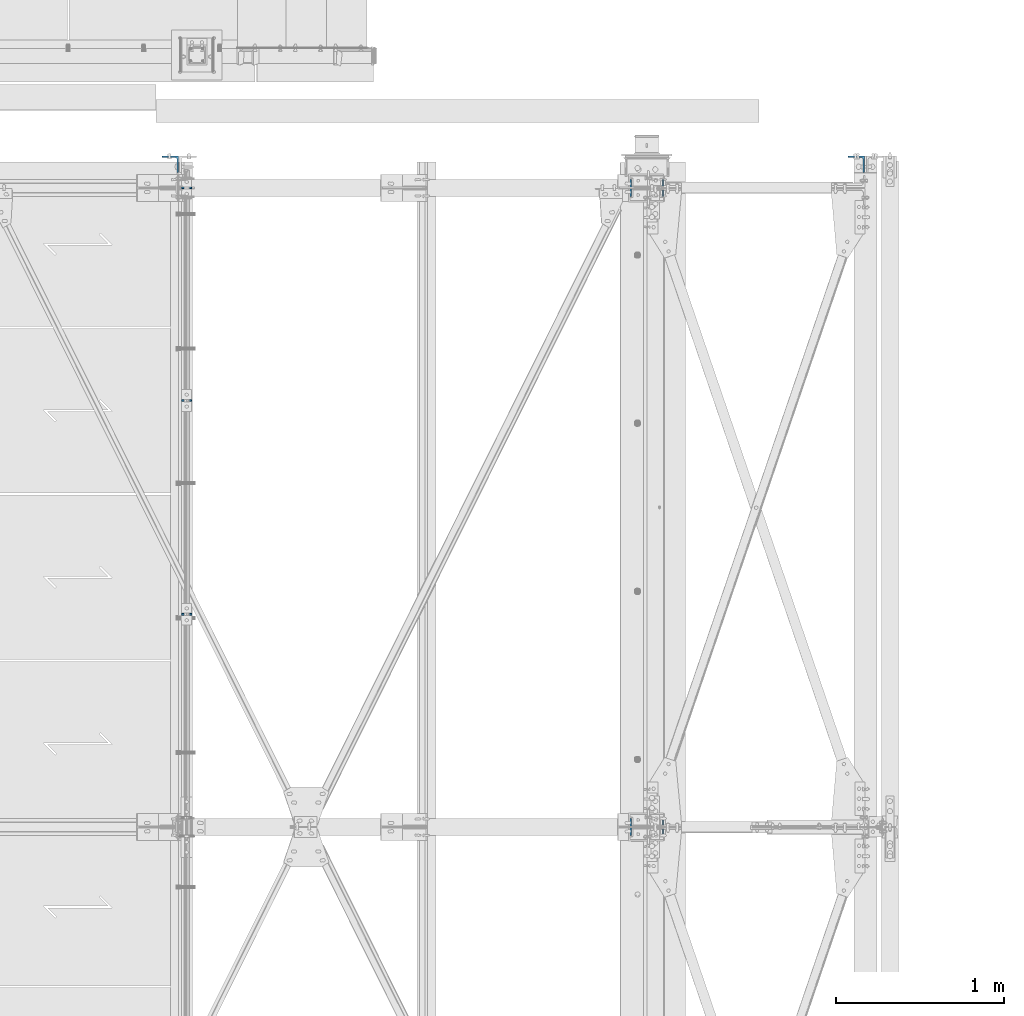
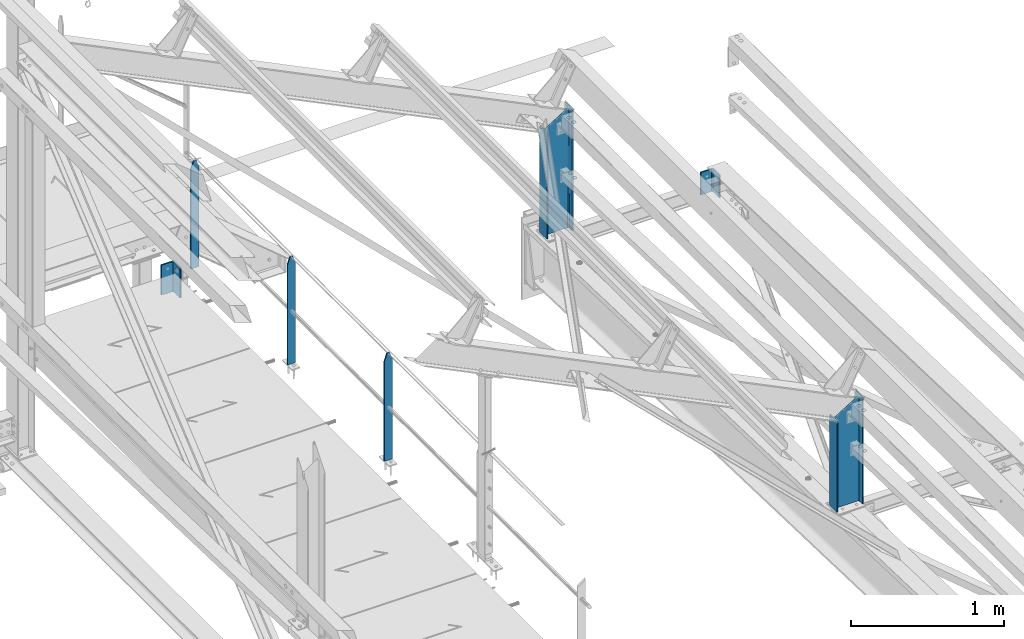
# One storey, part 39 of 496: 7 columns, 5 elements without a shape of their own.
"""IFC2X3 building model written with IfcOpenShell, lengths in millimetres."""

from ifc_helpers import new_model, si_unit, frame, origin_with_axes, origin_2d_with_axis, place, context, subcontext, project, spatial, rectangle, i_section, l_section, extrude, clip, halfspace, material, type_object, element, aggregate, save


model = new_model("IFC2X3")

# Units and contexts
model_context = context("Model", 3, precision=1e-05, world=origin_with_axes())
body_context = subcontext(model_context, "Body", "Model", "MODEL_VIEW")
ifc_project = project(units=[si_unit("LENGTHUNIT", "METRE", prefix="MILLI"), si_unit("AREAUNIT", "SQUARE_METRE"), si_unit("VOLUMEUNIT", "CUBIC_METRE"), si_unit("MASSUNIT", "GRAM", prefix="KILO"), si_unit("TIMEUNIT", "SECOND"), si_unit("PLANEANGLEUNIT", "RADIAN"), si_unit("SOLIDANGLEUNIT", "STERADIAN"), si_unit("THERMODYNAMICTEMPERATUREUNIT", "DEGREE_CELSIUS"), si_unit("LUMINOUSINTENSITYUNIT", "LUMEN")], contexts=[model_context])

# Site, building, storey
site_placement = place(None, origin_with_axes())
site = spatial("IfcSite", under=ifc_project, at=site_placement, CompositionType="ELEMENT")
building_placement = place(site_placement, origin_with_axes())
building = spatial("IfcBuilding", under=site, at=building_placement, Name="Undefined", CompositionType="ELEMENT")
storey_placement = place(building_placement, origin_with_axes())
storey = spatial("IfcBuildingStorey", under=building, at=storey_placement, Name="Undefined", CompositionType="ELEMENT", Elevation=0.0)

# Assembly, columns
assembly_1_placement = place(storey_placement, origin_with_axes())
assembly_1 = element("IfcElementAssembly", 1, at=assembly_1_placement, inside=storey, Name="MAIN COURANTE", AssemblyPlace="NOTDEFINED", PredefinedType="NOTDEFINED")
ifc_material_1 = material(Name="Undefined/S235-E24")
column_type_1 = type_object("IfcColumnType", PredefinedType="NOTDEFINED")
column_1_placement = place(assembly_1_placement, frame((35593.9917224402, 15200.0000000319, 8249.99999828729), z_axis=(0.0, 0.0, 1.0), x_axis=(1.0, 0.0, 0.0)))
column_1 = element("IfcColumn", 2, at=column_1_placement, type_object=column_type_1, material=ifc_material_1, Name="MONTANT", context=body_context, shape_type="Clipping", body=[
    clip(clip(extrude(rectangle(XDim=10.0, YDim=60.0, at=origin_2d_with_axis()), frame((0.0, 0.0, 857.599997130677), z_axis=(0.0, 0.0, -1.0), x_axis=(0.0, 1.0, 0.0)), (0.0, 0.0, 1.0), 857.6), halfspace(frame((30.0000001657245, -5.000000004674, 797.599997170884), z_axis=(0.948683298050514, 0.0, 0.316227766016838), x_axis=(-0.316227766016838, 0.0, 0.948683298050514)), False)), halfspace(frame((-29.9999998342682, 4.99999999524351, 797.599997177174), z_axis=(-0.948683298050514, 0.0, 0.316227766016838), x_axis=(0.316227766016838, 0.0, 0.948683298050514)), False)),
])
column_2_placement = place(assembly_1_placement, frame((35593.9917204131, 12665.0034319655, 8250.00000011892), z_axis=(0.0, 0.0, 1.0), x_axis=(1.0, 0.0, 0.0)))
column_2 = element("IfcColumn", 3, at=column_2_placement, type_object=column_type_1, material=ifc_material_1, Name="MONTANT", context=body_context, shape_type="Clipping", body=[
    clip(clip(extrude(rectangle(XDim=10.0, YDim=60.0, at=origin_2d_with_axis()), frame((0.0, 0.0, 857.599997130677), z_axis=(0.0, 0.0, -1.0), x_axis=(0.0, 1.0, 0.0)), (0.0, 0.0, 1.0), 857.6), halfspace(frame((30.0000001657245, -5.000000004674, 797.599997170884), z_axis=(0.948683298050514, 0.0, 0.316227766016838), x_axis=(-0.316227766016838, 0.0, 0.948683298050514)), False)), halfspace(frame((-29.9999998342682, 4.99999999524351, 797.599997177174), z_axis=(-0.948683298050514, 0.0, 0.316227766016838), x_axis=(0.316227766016838, 0.0, 0.948683298050514)), False)),
])
column_3_placement = place(assembly_1_placement, frame((35593.9917214683, 13935.0034319655, 8249.99999924836), z_axis=(0.0, 0.0, 1.0), x_axis=(1.0, 0.0, 0.0)))
column_3 = element("IfcColumn", 4, at=column_3_placement, type_object=column_type_1, material=ifc_material_1, Name="MONTANT", context=body_context, shape_type="Clipping", body=[
    clip(clip(extrude(rectangle(XDim=10.0, YDim=60.0, at=origin_2d_with_axis()), frame((0.0, 0.0, 857.599997130677), z_axis=(0.0, 0.0, -1.0), x_axis=(0.0, 1.0, 0.0)), (0.0, 0.0, 1.0), 857.6), halfspace(frame((30.0000001657245, -5.000000004674, 797.599997170884), z_axis=(0.948683298050514, 0.0, 0.316227766016838), x_axis=(-0.316227766016838, 0.0, 0.948683298050514)), False)), halfspace(frame((-29.9999998342682, 4.99999999524351, 797.599997177174), z_axis=(-0.948683298050514, 0.0, 0.316227766016838), x_axis=(0.316227766016838, 0.0, 0.948683298050514)), False)),
])
aggregate(assembly_1, [column_1, column_2, column_3])

# Assembly, column
assembly_2_placement = place(storey_placement, origin_with_axes())
assembly_2 = element("IfcElementAssembly", 5, at=assembly_2_placement, inside=storey, AssemblyPlace="NOTDEFINED", PredefinedType="NOTDEFINED")
column_type_2 = type_object("IfcColumnType", PredefinedType="NOTDEFINED")
column_4_placement = place(assembly_2_placement, frame((35496.4917140614, 15339.9999999683, 7970.00437164953), z_axis=(0.0, 0.0, 1.0), x_axis=(-1.0, 0.0, 0.0)))
column_4 = element("IfcColumn", 6, at=column_4_placement, type_object=column_type_2, material=ifc_material_1, context=body_context, shape_type="SweptSolid", body=[
    extrude(l_section(Depth=100.0, Width=100.0, Thickness=10.0, FilletRadius=12.0, EdgeRadius=6.0, at=origin_2d_with_axis()), frame((0.0, 0.0, 239.999999999999), z_axis=(0.0, 0.0, -1.0), x_axis=(0.0, 1.0, 0.0)), (0.0, 0.0, 1.0), 240.0),
])
aggregate(assembly_2, [column_4])

assembly_3_placement = place(storey_placement, origin_with_axes())
assembly_3 = element("IfcElementAssembly", 7, at=assembly_3_placement, inside=storey, AssemblyPlace="NOTDEFINED", PredefinedType="NOTDEFINED")
column_5_placement = place(assembly_3_placement, frame((39575.0000000118, 15339.999993069, 7343.32582688961), z_axis=(0.0, 0.0, 1.0), x_axis=(-1.0, 0.0, 0.0)))
column_5 = element("IfcColumn", 8, at=column_5_placement, type_object=column_type_2, material=ifc_material_1, context=body_context, shape_type="SweptSolid", body=[
    extrude(l_section(Depth=100.0, Width=100.0, Thickness=10.0, FilletRadius=12.0, EdgeRadius=6.0, at=origin_2d_with_axis()), frame((0.0, 0.0, 180.0), z_axis=(0.0, 0.0, -1.0), x_axis=(0.0, 1.0, 0.0)), (0.0, 0.0, 1.0), 180.0),
])
aggregate(assembly_3, [column_5])

assembly_4_placement = place(storey_placement, origin_with_axes())
assembly_4 = element("IfcElementAssembly", 9, at=assembly_4_placement, inside=storey, Name="TRAVERSE SHED", AssemblyPlace="NOTDEFINED", PredefinedType="NOTDEFINED")
ifc_material_2 = material(Name="Undefined/S275-E28")
column_type_3 = type_object("IfcColumnType", Name="IPE200", PredefinedType="NOTDEFINED")
column_6_placement = place(assembly_4_placement, frame((38330.0, 15200.0, 7572.3207892609), z_axis=(0.0, 0.0, 1.0), x_axis=(-1.0, 0.0, 0.0)))
column_6 = element("IfcColumn", 10, at=column_6_placement, type_object=column_type_3, material=ifc_material_2, Name="TRAVERSE SHED", ObjectType="IPE200", context=body_context, shape_type="Clipping", body=[
    clip(clip(extrude(i_section(OverallWidth=100.0, OverallDepth=200.0, WebThickness=5.599999905, FlangeThickness=8.5, FilletRadius=12.0, at=origin_2d_with_axis()), frame((0.0, 0.0, 979.888907582708), z_axis=(0.0, 0.0, -1.0), x_axis=(0.0, 1.0, 0.0)), (0.0, 0.0, 1.0), 1034.36), halfspace(frame((100.0, 15200.0, 853.14611483338), z_axis=(-0.528573112142588, 0.0, -0.848887781229003), x_axis=(0.0, 1.0, 0.0)), True)), halfspace(frame((0.0, -43.0853770966241, 8.65091138601929), z_axis=(0.0, -0.0314108809853773, 0.999506556534634), x_axis=(-1.0, 0.0, 0.0)), True)),
])
aggregate(assembly_4, [column_6])

assembly_5_placement = place(storey_placement, origin_with_axes())
assembly_5 = element("IfcElementAssembly", 11, at=assembly_5_placement, inside=storey, Name="TRAVERSE SHED", AssemblyPlace="NOTDEFINED", PredefinedType="NOTDEFINED")
column_7_placement = place(assembly_5_placement, frame((38330.0, 11400.0, 7691.74106035886), z_axis=(0.0, 0.0, 1.0), x_axis=(-1.0, 0.0, 0.0)))
column_7 = element("IfcColumn", 12, at=column_7_placement, type_object=column_type_3, material=ifc_material_2, Name="TRAVERSE SHED", ObjectType="IPE200", context=body_context, shape_type="Clipping", body=[
    clip(clip(extrude(i_section(OverallWidth=100.0, OverallDepth=200.0, WebThickness=5.599999905, FlangeThickness=8.5, FilletRadius=12.0, at=origin_2d_with_axis()), frame((0.0, 0.0, 860.468636484741), z_axis=(0.0, 0.0, -1.0), x_axis=(0.0, 1.0, 0.0)), (0.0, 0.0, 1.0), 914.94), halfspace(frame((100.0, 11400.0, 733.725843735414), z_axis=(-0.528573112142588, 0.0, -0.848887781229003), x_axis=(0.0, 1.0, 0.0)), True)), halfspace(frame((0.0, -66.0396412320715, 7.92954558049769), z_axis=(0.0, 0.031410477145298, -0.999506569225788), x_axis=(1.0, 0.0, 0.0)), False)),
])
aggregate(assembly_5, [column_7])

save(model, "model.ifc")
